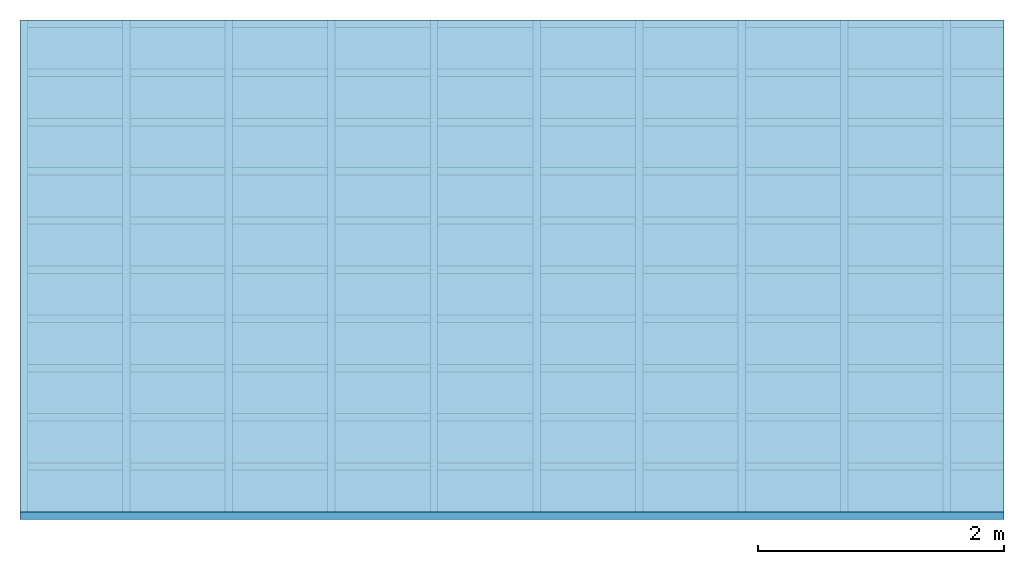
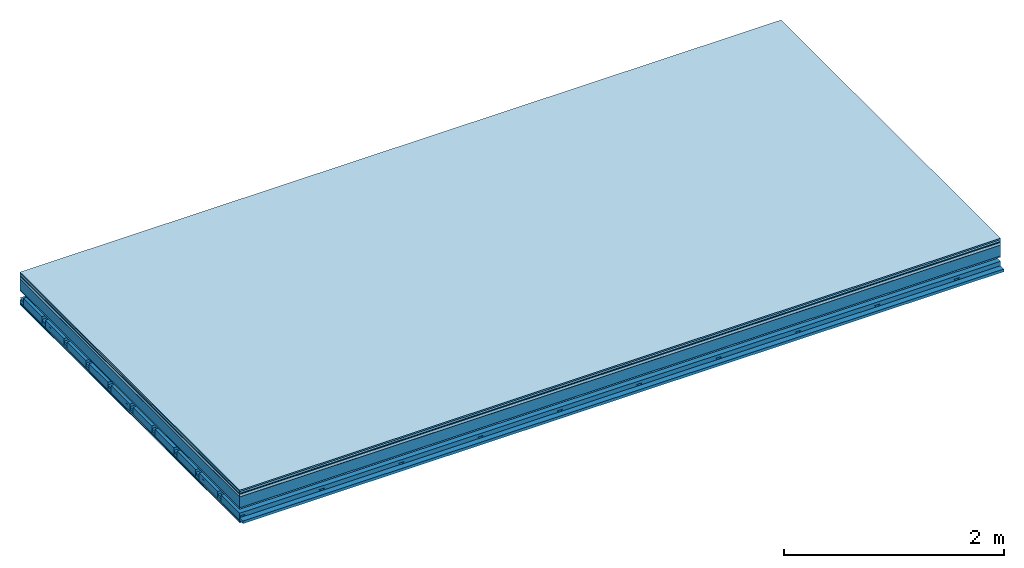
# One storey: 9 plates, 4 members, 1 element without a shape of its own.
"""IFC4 building model written with IfcOpenShell, lengths in metres."""

from ifc_helpers import new_model, si_unit, derived_unit, direction, frame, frame_2d, origin, origin_with_axes, place, context, project, spatial, polyline, rectangle, outline, extrude, material, layer, layer_set, type_object, element, aggregate, save


model = new_model("IFC4")

# Units and contexts
plan_context = context("Plan", 3, precision=1e-05, world=origin(), true_north=direction((0.0, 1.0)))
model_context = context("Model", 3, precision=1e-05, world=origin(), true_north=direction((0.0, 1.0)))
ifc_project = project(units=[si_unit("LENGTHUNIT", "METRE"), derived_unit("SOUNDPRESSUREUNIT", [(si_unit("PRESSUREUNIT", "PASCAL", prefix="MICRO"), 0)]), si_unit("ENERGYUNIT", "JOULE", prefix="MEGA"), si_unit("MASSUNIT", "GRAM", prefix="KILO"), derived_unit("THERMALTRANSMITTANCEUNIT", [(si_unit("POWERUNIT", "WATT"), 1), (si_unit("AREAUNIT", "SQUARE_METRE"), -1), (si_unit("THERMODYNAMICTEMPERATUREUNIT", "KELVIN"), -1)]), derived_unit("AREADENSITYUNIT", [(si_unit("MASSUNIT", "GRAM", prefix="KILO"), 1), (si_unit("AREAUNIT", "SQUARE_METRE"), -1)]), derived_unit("USERDEFINED", [(si_unit("ENERGYUNIT", "JOULE", prefix="MEGA"), 1), (si_unit("AREAUNIT", "SQUARE_METRE"), -1)])], contexts=[plan_context, model_context])

# Site, building, storey
site = spatial("IfcSite", under=ifc_project)
building_placement = place(None, origin())
building = spatial("IfcBuilding", under=site, at=building_placement)
storey_placement = place(building_placement, origin())
storey = spatial("IfcBuildingStorey", under=building, at=storey_placement)

# Slab, members, plates
ifc_material_1 = material(Category="11.013")
ifc_layer_1 = layer(ifc_material_1, 0.015, Name="Flooring")
ifc_material_2 = material(Category="03.007")
ifc_layer_2 = layer(ifc_material_2, 0.02, Name="On-material")
ifc_material_3 = material(Name="Wood fiber generic product", Category="10.009")
ifc_layer_3 = layer(ifc_material_3, 0.01, Name="Impact sound insulation")
ifc_material_4 = material(Name="with broken")
ifc_layer_4 = layer(ifc_material_4, 0.03, Name="on Supporting structure")
ifc_material_5 = material(Name="protection", Category="09.007")
ifc_layer_5 = layer(ifc_material_5, 0.0005, Name="Sub-floor")
ifc_material_6 = material(Name="no composite action")
ifc_layer_6 = layer(ifc_material_6, 0.0, Name="Bond")
ifc_layer_7 = layer(None, 0.12, Name="Supporting structure")
ifc_material_7 = material(Name="of the art")
ifc_layer_8 = layer(ifc_material_7, 0.0, Name="Bond")
ifc_layer_9 = layer(ifc_material_2, 0.015, Name="Lower layer 1")
ifc_layer_10 = layer(None, 0.095, Name="Coupling")
ifc_layer_11 = layer(None, 0.03, Name="Battens / profiles")
ifc_material_8 = material(Name="Plasterboard type A", Category="03.008")
ifc_layer_12 = layer(ifc_material_8, 0.0125, Name="Ceiling covering 1st layer")
ifc_layer_13 = layer(ifc_material_8, 0.0125, Name="Ceiling covering layer 2")
ifc_material_9 = material(Category="04.001")
ifc_layer_14 = layer(ifc_material_9, 0.003, Name="Surface / treatment")
ifc_layer_set = layer_set([ifc_layer_1, ifc_layer_2, ifc_layer_3, ifc_layer_4, ifc_layer_5, ifc_layer_6, ifc_layer_7, ifc_layer_8, ifc_layer_9, ifc_layer_10, ifc_layer_11, ifc_layer_12, ifc_layer_13, ifc_layer_14])
slab_type = type_object("IfcSlabType", Name="A2123", PredefinedType="NOTDEFINED", material=ifc_layer_set)
slab_placement = place(None, frame((0.0, 0.0, 0.0), z_axis=(0.0, 0.0, -1.0), x_axis=(1.0, 0.0, 0.0)))
slab = element("IfcSlab", 1, at=slab_placement, inside=storey, type_object=slab_type, material=ifc_layer_set, Name="Slab #1")
ifc_material_10 = material(Name="Solid timber panel")
member_1_placement = place(slab_placement, origin())
member_1 = element("IfcMember", 2, at=member_1_placement, material=ifc_material_10, Name="Supporting structure", context=plan_context, shape_type="SweptSolid", body=[
    extrude(rectangle(XDim=1.0, YDim=0.12, at=frame_2d((0.5, 0.06), x_axis=(1.0, 0.0))), frame((0.0, 4.0, 0.0755), z_axis=(0.0, -1.0, 0.0), x_axis=(1.0, 0.0, 0.0)), (0.0, 0.0, 1.0), 4.0),
    extrude(rectangle(XDim=1.0, YDim=0.12, at=frame_2d((0.5, 0.06), x_axis=(1.0, 0.0))), frame((1.0, 4.0, 0.0755), z_axis=(0.0, -1.0, 0.0), x_axis=(1.0, 0.0, 0.0)), (0.0, 0.0, 1.0), 4.0),
    extrude(rectangle(XDim=1.0, YDim=0.12, at=frame_2d((0.5, 0.06), x_axis=(1.0, 0.0))), frame((2.0, 4.0, 0.0755), z_axis=(0.0, -1.0, 0.0), x_axis=(1.0, 0.0, 0.0)), (0.0, 0.0, 1.0), 4.0),
    extrude(rectangle(XDim=1.0, YDim=0.12, at=frame_2d((0.5, 0.06), x_axis=(1.0, 0.0))), frame((3.0, 4.0, 0.0755), z_axis=(0.0, -1.0, 0.0), x_axis=(1.0, 0.0, 0.0)), (0.0, 0.0, 1.0), 4.0),
    extrude(rectangle(XDim=1.0, YDim=0.12, at=frame_2d((0.5, 0.06), x_axis=(1.0, 0.0))), frame((4.0, 4.0, 0.0755), z_axis=(0.0, -1.0, 0.0), x_axis=(1.0, 0.0, 0.0)), (0.0, 0.0, 1.0), 4.0),
    extrude(rectangle(XDim=1.0, YDim=0.12, at=frame_2d((0.5, 0.06), x_axis=(1.0, 0.0))), frame((5.0, 4.0, 0.0755), z_axis=(0.0, -1.0, 0.0), x_axis=(1.0, 0.0, 0.0)), (0.0, 0.0, 1.0), 4.0),
    extrude(rectangle(XDim=1.0, YDim=0.12, at=frame_2d((0.5, 0.06), x_axis=(1.0, 0.0))), frame((6.0, 4.0, 0.0755), z_axis=(0.0, -1.0, 0.0), x_axis=(1.0, 0.0, 0.0)), (0.0, 0.0, 1.0), 4.0),
    extrude(rectangle(XDim=1.0, YDim=0.12, at=frame_2d((0.5, 0.06), x_axis=(1.0, 0.0))), frame((7.0, 4.0, 0.0755), z_axis=(0.0, -1.0, 0.0), x_axis=(1.0, 0.0, 0.0)), (0.0, 0.0, 1.0), 4.0),
])
ifc_material_11 = material()
member_2_placement = place(slab_placement, origin())
member_2 = element("IfcMember", 3, at=member_2_placement, material=ifc_material_11, Name="Coupling", context=plan_context, shape_type="SweptSolid", body=[
    extrude(outline(polyline([(0.0, 0.0), (0.06, 0.0), (0.04, 0.02), (0.02, 0.02), (0.0, 0.0)])), frame((0.0, 4.0, 0.2855), z_axis=(0.0, -1.0, 0.0), x_axis=(1.0, 0.0, 0.0)), (0.0, 0.0, 1.0), 4.0),
    extrude(outline(polyline([(0.0, 0.0), (0.06, 0.0), (0.04, 0.02), (0.02, 0.02), (0.0, 0.0)])), frame((0.834, 4.0, 0.2855), z_axis=(0.0, -1.0, 0.0), x_axis=(1.0, 0.0, 0.0)), (0.0, 0.0, 1.0), 4.0),
    extrude(outline(polyline([(0.0, 0.0), (0.06, 0.0), (0.04, 0.02), (0.02, 0.02), (0.0, 0.0)])), frame((1.668, 4.0, 0.2855), z_axis=(0.0, -1.0, 0.0), x_axis=(1.0, 0.0, 0.0)), (0.0, 0.0, 1.0), 4.0),
    extrude(outline(polyline([(0.0, 0.0), (0.06, 0.0), (0.04, 0.02), (0.02, 0.02), (0.0, 0.0)])), frame((2.502, 4.0, 0.2855), z_axis=(0.0, -1.0, 0.0), x_axis=(1.0, 0.0, 0.0)), (0.0, 0.0, 1.0), 4.0),
    extrude(outline(polyline([(0.0, 0.0), (0.06, 0.0), (0.04, 0.02), (0.02, 0.02), (0.0, 0.0)])), frame((3.336, 4.0, 0.2855), z_axis=(0.0, -1.0, 0.0), x_axis=(1.0, 0.0, 0.0)), (0.0, 0.0, 1.0), 4.0),
    extrude(outline(polyline([(0.0, 0.0), (0.06, 0.0), (0.04, 0.02), (0.02, 0.02), (0.0, 0.0)])), frame((4.17, 4.0, 0.2855), z_axis=(0.0, -1.0, 0.0), x_axis=(1.0, 0.0, 0.0)), (0.0, 0.0, 1.0), 4.0),
    extrude(outline(polyline([(0.0, 0.0), (0.06, 0.0), (0.04, 0.02), (0.02, 0.02), (0.0, 0.0)])), frame((5.004, 4.0, 0.2855), z_axis=(0.0, -1.0, 0.0), x_axis=(1.0, 0.0, 0.0)), (0.0, 0.0, 1.0), 4.0),
    extrude(outline(polyline([(0.0, 0.0), (0.06, 0.0), (0.04, 0.02), (0.02, 0.02), (0.0, 0.0)])), frame((5.838, 4.0, 0.2855), z_axis=(0.0, -1.0, 0.0), x_axis=(1.0, 0.0, 0.0)), (0.0, 0.0, 1.0), 4.0),
    extrude(outline(polyline([(0.0, 0.0), (0.06, 0.0), (0.04, 0.02), (0.02, 0.02), (0.0, 0.0)])), frame((6.672, 4.0, 0.2855), z_axis=(0.0, -1.0, 0.0), x_axis=(1.0, 0.0, 0.0)), (0.0, 0.0, 1.0), 4.0),
    extrude(outline(polyline([(0.0, 0.0), (0.06, 0.0), (0.04, 0.02), (0.02, 0.02), (0.0, 0.0)])), frame((7.506, 4.0, 0.2855), z_axis=(0.0, -1.0, 0.0), x_axis=(1.0, 0.0, 0.0)), (0.0, 0.0, 1.0), 4.0),
])
member_3_placement = place(slab_placement, origin())
member_3 = element("IfcMember", 4, at=member_3_placement, material=ifc_material_11, Name="Battens / profiles", context=plan_context, shape_type="SweptSolid", body=[
    extrude(rectangle(XDim=0.06, YDim=0.03, at=frame_2d((0.03, 0.015), x_axis=(1.0, 0.0))), frame((0.0, 0.0, 0.3055), z_axis=(1.0, 0.0, 0.0), x_axis=(0.0, 1.0, 0.0)), (0.0, 0.0, 1.0), 8.0),
    extrude(rectangle(XDim=0.06, YDim=0.03, at=frame_2d((0.03, 0.015), x_axis=(1.0, 0.0))), frame((0.0, 0.4, 0.3055), z_axis=(1.0, 0.0, 0.0), x_axis=(0.0, 1.0, 0.0)), (0.0, 0.0, 1.0), 8.0),
    extrude(rectangle(XDim=0.06, YDim=0.03, at=frame_2d((0.03, 0.015), x_axis=(1.0, 0.0))), frame((0.0, 0.8, 0.3055), z_axis=(1.0, 0.0, 0.0), x_axis=(0.0, 1.0, 0.0)), (0.0, 0.0, 1.0), 8.0),
    extrude(rectangle(XDim=0.06, YDim=0.03, at=frame_2d((0.03, 0.015), x_axis=(1.0, 0.0))), frame((0.0, 1.2, 0.3055), z_axis=(1.0, 0.0, 0.0), x_axis=(0.0, 1.0, 0.0)), (0.0, 0.0, 1.0), 8.0),
    extrude(rectangle(XDim=0.06, YDim=0.03, at=frame_2d((0.03, 0.015), x_axis=(1.0, 0.0))), frame((0.0, 1.6, 0.3055), z_axis=(1.0, 0.0, 0.0), x_axis=(0.0, 1.0, 0.0)), (0.0, 0.0, 1.0), 8.0),
    extrude(rectangle(XDim=0.06, YDim=0.03, at=frame_2d((0.03, 0.015), x_axis=(1.0, 0.0))), frame((0.0, 2.0, 0.3055), z_axis=(1.0, 0.0, 0.0), x_axis=(0.0, 1.0, 0.0)), (0.0, 0.0, 1.0), 8.0),
    extrude(rectangle(XDim=0.06, YDim=0.03, at=frame_2d((0.03, 0.015), x_axis=(1.0, 0.0))), frame((0.0, 2.4, 0.3055), z_axis=(1.0, 0.0, 0.0), x_axis=(0.0, 1.0, 0.0)), (0.0, 0.0, 1.0), 8.0),
    extrude(rectangle(XDim=0.06, YDim=0.03, at=frame_2d((0.03, 0.015), x_axis=(1.0, 0.0))), frame((0.0, 2.8, 0.3055), z_axis=(1.0, 0.0, 0.0), x_axis=(0.0, 1.0, 0.0)), (0.0, 0.0, 1.0), 8.0),
    extrude(rectangle(XDim=0.06, YDim=0.03, at=frame_2d((0.03, 0.015), x_axis=(1.0, 0.0))), frame((0.0, 3.2, 0.3055), z_axis=(1.0, 0.0, 0.0), x_axis=(0.0, 1.0, 0.0)), (0.0, 0.0, 1.0), 8.0),
    extrude(rectangle(XDim=0.06, YDim=0.03, at=frame_2d((0.03, 0.015), x_axis=(1.0, 0.0))), frame((0.0, 3.6, 0.3055), z_axis=(1.0, 0.0, 0.0), x_axis=(0.0, 1.0, 0.0)), (0.0, 0.0, 1.0), 8.0),
    extrude(rectangle(XDim=0.06, YDim=0.03, at=frame_2d((0.03, 0.015), x_axis=(1.0, 0.0))), frame((0.0, 4.0, 0.3055), z_axis=(1.0, 0.0, 0.0), x_axis=(0.0, 1.0, 0.0)), (0.0, 0.0, 1.0), 8.0),
])
ifc_material_12 = material()
member_4_placement = place(slab_placement, origin())
member_4 = element("IfcMember", 5, at=member_4_placement, material=ifc_material_12, Name="Cavity", context=plan_context, shape_type="SweptSolid", body=[
    extrude(rectangle(XDim=0.34, YDim=0.08, at=frame_2d((0.17, 0.04), x_axis=(1.0, 0.0))), frame((0.0, 0.06, 0.2555), z_axis=(1.0, 0.0, 0.0), x_axis=(0.0, 1.0, 0.0)), (0.0, 0.0, 1.0), 8.0),
    extrude(rectangle(XDim=0.34, YDim=0.08, at=frame_2d((0.17, 0.04), x_axis=(1.0, 0.0))), frame((0.0, 0.46, 0.2555), z_axis=(1.0, 0.0, 0.0), x_axis=(0.0, 1.0, 0.0)), (0.0, 0.0, 1.0), 8.0),
    extrude(rectangle(XDim=0.34, YDim=0.08, at=frame_2d((0.17, 0.04), x_axis=(1.0, 0.0))), frame((0.0, 0.86, 0.2555), z_axis=(1.0, 0.0, 0.0), x_axis=(0.0, 1.0, 0.0)), (0.0, 0.0, 1.0), 8.0),
    extrude(rectangle(XDim=0.34, YDim=0.08, at=frame_2d((0.17, 0.04), x_axis=(1.0, 0.0))), frame((0.0, 1.26, 0.2555), z_axis=(1.0, 0.0, 0.0), x_axis=(0.0, 1.0, 0.0)), (0.0, 0.0, 1.0), 8.0),
    extrude(rectangle(XDim=0.34, YDim=0.08, at=frame_2d((0.17, 0.04), x_axis=(1.0, 0.0))), frame((0.0, 1.66, 0.2555), z_axis=(1.0, 0.0, 0.0), x_axis=(0.0, 1.0, 0.0)), (0.0, 0.0, 1.0), 8.0),
    extrude(rectangle(XDim=0.34, YDim=0.08, at=frame_2d((0.17, 0.04), x_axis=(1.0, 0.0))), frame((0.0, 2.06, 0.2555), z_axis=(1.0, 0.0, 0.0), x_axis=(0.0, 1.0, 0.0)), (0.0, 0.0, 1.0), 8.0),
    extrude(rectangle(XDim=0.34, YDim=0.08, at=frame_2d((0.17, 0.04), x_axis=(1.0, 0.0))), frame((0.0, 2.46, 0.2555), z_axis=(1.0, 0.0, 0.0), x_axis=(0.0, 1.0, 0.0)), (0.0, 0.0, 1.0), 8.0),
    extrude(rectangle(XDim=0.34, YDim=0.08, at=frame_2d((0.17, 0.04), x_axis=(1.0, 0.0))), frame((0.0, 2.86, 0.2555), z_axis=(1.0, 0.0, 0.0), x_axis=(0.0, 1.0, 0.0)), (0.0, 0.0, 1.0), 8.0),
    extrude(rectangle(XDim=0.34, YDim=0.08, at=frame_2d((0.17, 0.04), x_axis=(1.0, 0.0))), frame((0.0, 3.26, 0.2555), z_axis=(1.0, 0.0, 0.0), x_axis=(0.0, 1.0, 0.0)), (0.0, 0.0, 1.0), 8.0),
    extrude(rectangle(XDim=0.34, YDim=0.08, at=frame_2d((0.17, 0.04), x_axis=(1.0, 0.0))), frame((0.0, 3.66, 0.2555), z_axis=(1.0, 0.0, 0.0), x_axis=(0.0, 1.0, 0.0)), (0.0, 0.0, 1.0), 8.0),
])
plate_1_placement = place(slab_placement, origin())
plate_1 = element("IfcPlate", 6, at=plate_1_placement, material=ifc_material_1, Name="Flooring", context=plan_context, shape_type="SweptSolid", body=[
    extrude(rectangle(XDim=8.0, YDim=4.0, at=frame_2d((4.0, 2.0), x_axis=(1.0, 0.0))), origin_with_axes(), (0.0, 0.0, 1.0), 0.015),
])
plate_2_placement = place(slab_placement, origin())
plate_2 = element("IfcPlate", 7, at=plate_2_placement, material=ifc_material_2, Name="On-material", context=plan_context, shape_type="SweptSolid", body=[
    extrude(rectangle(XDim=8.0, YDim=4.0, at=frame_2d((4.0, 2.0), x_axis=(1.0, 0.0))), frame((0.0, 0.0, 0.015), z_axis=(0.0, 0.0, 1.0), x_axis=(1.0, 0.0, 0.0)), (0.0, 0.0, 1.0), 0.02),
])
plate_3_placement = place(slab_placement, origin())
plate_3 = element("IfcPlate", 8, at=plate_3_placement, material=ifc_material_3, Name="Impact sound insulation", context=plan_context, shape_type="SweptSolid", body=[
    extrude(rectangle(XDim=8.0, YDim=4.0, at=frame_2d((4.0, 2.0), x_axis=(1.0, 0.0))), frame((0.0, 0.0, 0.035), z_axis=(0.0, 0.0, 1.0), x_axis=(1.0, 0.0, 0.0)), (0.0, 0.0, 1.0), 0.01),
])
plate_4_placement = place(slab_placement, origin())
plate_4 = element("IfcPlate", 9, at=plate_4_placement, material=ifc_material_4, Name="on Supporting structure", context=plan_context, shape_type="SweptSolid", body=[
    extrude(rectangle(XDim=8.0, YDim=4.0, at=frame_2d((4.0, 2.0), x_axis=(1.0, 0.0))), frame((0.0, 0.0, 0.045), z_axis=(0.0, 0.0, 1.0), x_axis=(1.0, 0.0, 0.0)), (0.0, 0.0, 1.0), 0.03),
])
plate_5_placement = place(slab_placement, origin())
plate_5 = element("IfcPlate", 10, at=plate_5_placement, material=ifc_material_5, Name="Sub-floor", context=plan_context, shape_type="SweptSolid", body=[
    extrude(rectangle(XDim=8.0, YDim=4.0, at=frame_2d((4.0, 2.0), x_axis=(1.0, 0.0))), frame((0.0, 0.0, 0.075), z_axis=(0.0, 0.0, 1.0), x_axis=(1.0, 0.0, 0.0)), (0.0, 0.0, 1.0), 0.0005),
])
plate_6_placement = place(slab_placement, origin())
plate_6 = element("IfcPlate", 11, at=plate_6_placement, material=ifc_material_2, Name="Lower layer 1", context=plan_context, shape_type="SweptSolid", body=[
    extrude(rectangle(XDim=8.0, YDim=4.0, at=frame_2d((4.0, 2.0), x_axis=(1.0, 0.0))), frame((0.0, 0.0, 0.1955), z_axis=(0.0, 0.0, 1.0), x_axis=(1.0, 0.0, 0.0)), (0.0, 0.0, 1.0), 0.015),
])
plate_7_placement = place(slab_placement, origin())
plate_7 = element("IfcPlate", 12, at=plate_7_placement, material=ifc_material_8, Name="Ceiling covering 1st layer", context=plan_context, shape_type="SweptSolid", body=[
    extrude(rectangle(XDim=8.0, YDim=4.0, at=frame_2d((4.0, 2.0), x_axis=(1.0, 0.0))), frame((0.0, 0.0, 0.3355), z_axis=(0.0, 0.0, 1.0), x_axis=(1.0, 0.0, 0.0)), (0.0, 0.0, 1.0), 0.0125),
])
plate_8_placement = place(slab_placement, origin())
plate_8 = element("IfcPlate", 13, at=plate_8_placement, material=ifc_material_8, Name="Ceiling covering layer 2", context=plan_context, shape_type="SweptSolid", body=[
    extrude(rectangle(XDim=8.0, YDim=4.0, at=frame_2d((4.0, 2.0), x_axis=(1.0, 0.0))), frame((0.0, 0.0, 0.348), z_axis=(0.0, 0.0, 1.0), x_axis=(1.0, 0.0, 0.0)), (0.0, 0.0, 1.0), 0.0125),
])
plate_9_placement = place(slab_placement, origin())
plate_9 = element("IfcPlate", 14, at=plate_9_placement, material=ifc_material_9, Name="Surface / treatment", context=plan_context, shape_type="SweptSolid", body=[
    extrude(rectangle(XDim=8.0, YDim=4.0, at=frame_2d((4.0, 2.0), x_axis=(1.0, 0.0))), frame((0.0, 0.0, 0.3605), z_axis=(0.0, 0.0, 1.0), x_axis=(1.0, 0.0, 0.0)), (0.0, 0.0, 1.0), 0.003),
])
aggregate(slab, [plate_1, plate_2, plate_3, plate_4, plate_5, member_1, plate_6, member_2, member_3, member_4, plate_7, plate_8, plate_9])

save(model, "model.ifc")
